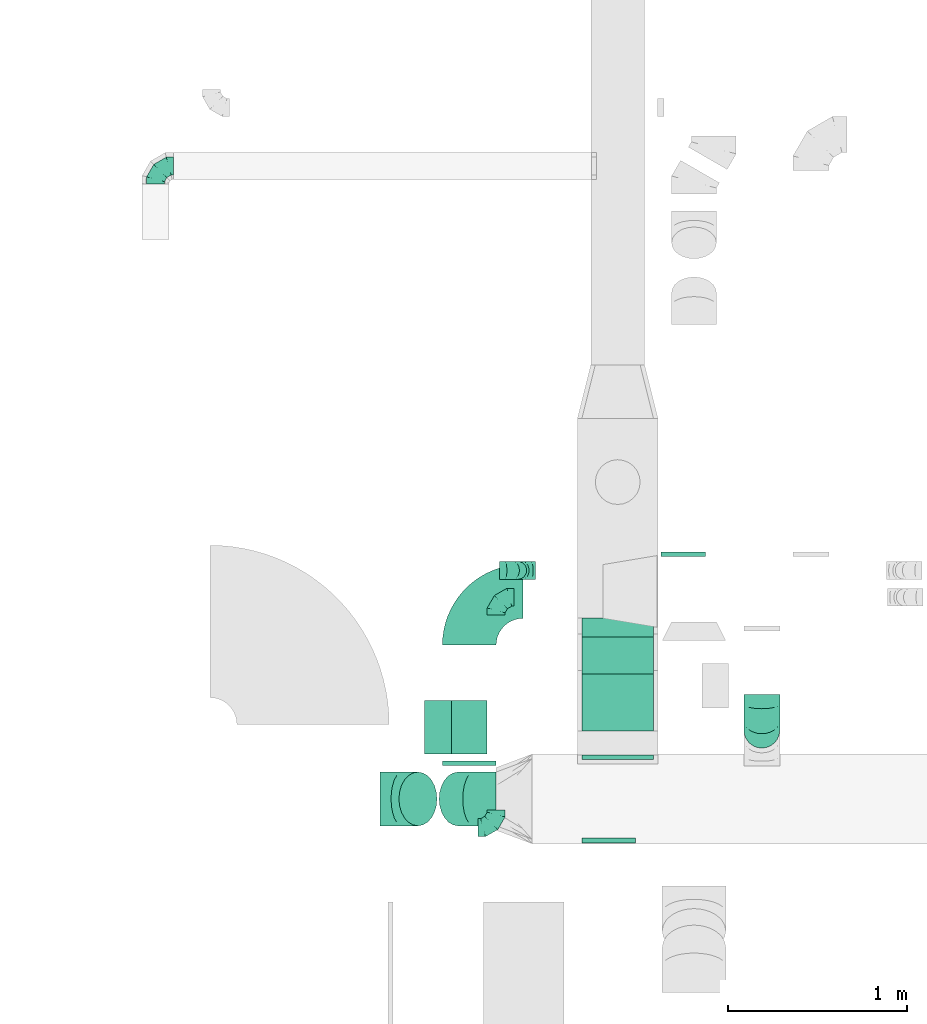
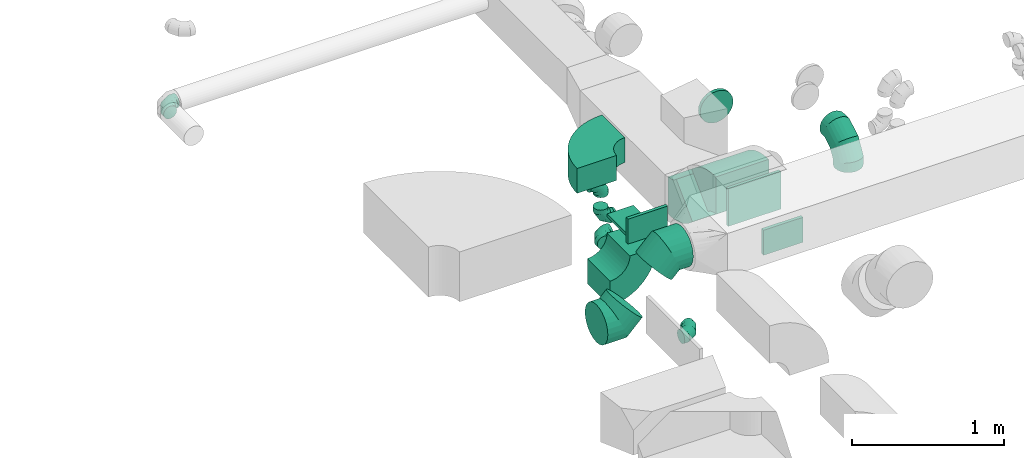
# One storey, part 29 of 62: 17 flow fittings.
"""IFC2X3 building model written with IfcOpenShell, lengths in millimetres."""

from ifc_helpers import new_model, entity, si_unit, converted_unit, derived_unit, direction, frame, frame_2d, origin, origin_2d_with_axis, place, context, subcontext, project, spatial, polyline, circle_curve, parameter, trimmed, segment, composite_curve, rectangle, outline, extrude, faceted_brep, source, transform, mapped, material, type_object, type_shapes, element, save


model = new_model("IFC2X3")

# Units and contexts
model_context = context("Model", 3, precision=0.01, world=origin(), true_north=direction((6.12303176911189e-17, 1.0)))
body_context = subcontext(model_context, "Body", "Model", "MODEL_VIEW")
ifc_project = project(units=[si_unit("LENGTHUNIT", "METRE", prefix="MILLI"), si_unit("AREAUNIT", "SQUARE_METRE"), si_unit("VOLUMEUNIT", "CUBIC_METRE"), converted_unit("PLANEANGLEUNIT", "DEGREE", entity("IfcRatioMeasure", 0.0174532925199433), si_unit("PLANEANGLEUNIT", "RADIAN"), dimensions=[0, 0, 0, 0, 0, 0, 0]), si_unit("MASSUNIT", "GRAM", prefix="KILO"), derived_unit("MASSDENSITYUNIT", [(si_unit("MASSUNIT", "GRAM", prefix="KILO"), 1), (si_unit("LENGTHUNIT", "METRE"), -3)]), derived_unit("MOMENTOFINERTIAUNIT", [(si_unit("LENGTHUNIT", "METRE"), 4)]), si_unit("TIMEUNIT", "SECOND"), si_unit("FREQUENCYUNIT", "HERTZ"), si_unit("THERMODYNAMICTEMPERATUREUNIT", "DEGREE_CELSIUS"), derived_unit("THERMALTRANSMITTANCEUNIT", [(si_unit("MASSUNIT", "GRAM", prefix="KILO"), 1), (si_unit("THERMODYNAMICTEMPERATUREUNIT", "KELVIN"), -1), (si_unit("TIMEUNIT", "SECOND"), -3)]), derived_unit("VOLUMETRICFLOWRATEUNIT", [(si_unit("LENGTHUNIT", "METRE"), 3), (si_unit("TIMEUNIT", "SECOND"), -1)]), derived_unit("MASSFLOWRATEUNIT", [(si_unit("MASSUNIT", "GRAM", prefix="KILO"), 1), (si_unit("TIMEUNIT", "SECOND"), -1)]), derived_unit("ROTATIONALFREQUENCYUNIT", [(si_unit("TIMEUNIT", "SECOND"), -1)]), si_unit("ELECTRICCURRENTUNIT", "AMPERE"), si_unit("ELECTRICVOLTAGEUNIT", "VOLT"), si_unit("POWERUNIT", "WATT"), si_unit("FORCEUNIT", "NEWTON", prefix="KILO"), si_unit("ILLUMINANCEUNIT", "LUX"), si_unit("LUMINOUSFLUXUNIT", "LUMEN"), si_unit("LUMINOUSINTENSITYUNIT", "CANDELA"), derived_unit("USERDEFINED", [(si_unit("MASSUNIT", "GRAM", prefix="KILO"), -1), (si_unit("LENGTHUNIT", "METRE"), -2), (si_unit("TIMEUNIT", "SECOND"), 3), (si_unit("LUMINOUSFLUXUNIT", "LUMEN"), 1)]), derived_unit("LINEARVELOCITYUNIT", [(si_unit("LENGTHUNIT", "METRE"), 1), (si_unit("TIMEUNIT", "SECOND"), -1)]), si_unit("PRESSUREUNIT", "PASCAL"), derived_unit("USERDEFINED", [(si_unit("LENGTHUNIT", "METRE"), -2), (si_unit("MASSUNIT", "GRAM", prefix="KILO"), 1), (si_unit("TIMEUNIT", "SECOND"), -2)]), derived_unit("LINEARFORCEUNIT", [(si_unit("MASSUNIT", "GRAM", prefix="KILO"), 1), (si_unit("LENGTHUNIT", "METRE"), 1), (si_unit("TIMEUNIT", "SECOND"), -2), (si_unit("LENGTHUNIT", "METRE"), -1)]), derived_unit("PLANARFORCEUNIT", [(si_unit("MASSUNIT", "GRAM", prefix="KILO"), 1), (si_unit("LENGTHUNIT", "METRE"), 1), (si_unit("TIMEUNIT", "SECOND"), -2), (si_unit("LENGTHUNIT", "METRE"), -2)])], contexts=[model_context])

# Site, building, storey
site_placement = place(None, origin())
site = spatial("IfcSite", under=ifc_project, at=site_placement, CompositionType="ELEMENT")
building_placement = place(site_placement, origin())
building = spatial("IfcBuilding", under=site, at=building_placement, CompositionType="ELEMENT")
storey_placement = place(building_placement, frame((0.0, 0.0, 24000.0)))
storey = spatial("IfcBuildingStorey", under=building, at=storey_placement, CompositionType="ELEMENT", Elevation=24000.0)

# Flow fittings
ifc_material = material()
duct_fitting_type_1 = type_object("IfcDuctFittingType", PredefinedType="NOTDEFINED", material=ifc_material)
shared_shape_1 = source(origin(), body_context, "Body", "SweptSolid", [
    extrude(rectangle(XDim=26.096000000001, YDim=300.0, at=origin_2d_with_axis()), frame((6.95, 0.0, -100.0)), (0.0, 0.0, 1.0), 200.0),
])
type_shapes(duct_fitting_type_1, [shared_shape_1])
flow_fitting_1_placement = place(storey_placement, frame((39266.85, 9324.41, 3550.0), z_axis=(1.0, 0.0, 0.0), x_axis=(0.0, 0.0, -1.0)))
element("IfcFlowFitting", 1, at=flow_fitting_1_placement, inside=storey, type_object=duct_fitting_type_1, material=ifc_material, context=body_context, shape_type="MappedRepresentation", body=[
    mapped(shared_shape_1, transform((0.0, 0.0, 0.0), scale=1.0)),
])
duct_fitting_type_2 = type_object("IfcDuctFittingType", PredefinedType="NOTDEFINED", material=ifc_material)
shared_shape_2 = source(origin(), body_context, "Body", "SweptSolid", [
    extrude(rectangle(XDim=300.0, YDim=26.096, at=origin_2d_with_axis()), frame((6.95, 0.0, -100.0), z_axis=(0.0, 0.0, 1.0), x_axis=(0.0, -1.0, 0.0)), (0.0, 0.0, 1.0), 200.0),
])
type_shapes(duct_fitting_type_2, [shared_shape_2])
flow_fitting_2_placement = place(storey_placement, frame((40045.11, 8699.98, 3550.0), z_axis=(0.0, 0.0, -1.0), x_axis=(0.0, -1.0, 0.0)))
element("IfcFlowFitting", 2, at=flow_fitting_2_placement, inside=storey, type_object=duct_fitting_type_2, material=ifc_material, context=body_context, shape_type="MappedRepresentation", body=[
    mapped(shared_shape_2, transform((0.0, 0.0, 0.0), scale=1.0)),
])
duct_fitting_type_3 = type_object("IfcDuctFittingType", PredefinedType="NOTDEFINED", material=ifc_material)
shared_shape_3 = source(origin(), body_context, "Body", "SweptSolid", [
    extrude(rectangle(XDim=26.0960000000006, YDim=400.0, at=origin_2d_with_axis()), frame((6.95, 0.0, -150.0)), (0.0, 0.0, 1.0), 300.0),
])
type_shapes(duct_fitting_type_3, [shared_shape_3])
flow_fitting_3_placement = place(storey_placement, frame((40095.11, 9149.98, 3550.0), z_axis=(0.0, 0.0, -1.0), x_axis=(0.0, 1.0, 0.0)))
element("IfcFlowFitting", 3, at=flow_fitting_3_placement, inside=storey, type_object=duct_fitting_type_3, material=ifc_material, context=body_context, shape_type="MappedRepresentation", body=[
    mapped(shared_shape_3, transform((0.0, 0.0, 0.0), scale=1.0)),
])
duct_fitting_type_4 = type_object("IfcDuctFittingType", PredefinedType="NOTDEFINED", material=ifc_material)
shared_shape_4 = source(origin(), body_context, "Body", "SweptSolid", [
    extrude(rectangle(XDim=24.9999999999999, YDim=300.0, at=origin_2d_with_axis()), frame((12.5, 0.0, -100.0)), (0.0, 0.0, 1.0), 200.0),
])
type_shapes(duct_fitting_type_4, [shared_shape_4])
flow_fitting_4_placement = place(storey_placement, frame((39266.85, 9137.41, 3650.0), z_axis=(0.0, 0.0, 1.0), x_axis=(0.0, -1.0, 0.0)))
element("IfcFlowFitting", 4, at=flow_fitting_4_placement, inside=storey, type_object=duct_fitting_type_4, material=ifc_material, context=body_context, shape_type="MappedRepresentation", body=[
    mapped(shared_shape_4, transform((0.0, 0.0, 0.0), scale=1.0)),
])
duct_fitting_type_5 = type_object("IfcDuctFittingType", PredefinedType="NOTDEFINED", material=ifc_material)
shared_shape_5 = source(origin(), body_context, "Body", "Brep", [
    faceted_brep([(-100.0, 0.0, -50.0), (-100.0, -12.94, -48.3), (-100.0, -25.0, -43.3), (-100.0, -35.36, -35.36), (-100.0, -43.3, -25.0), (-100.0, -48.3, -12.94), (-100.0, -50.0, 0.0), (-100.0, -48.3, 12.94), (-100.0, -43.3, 25.0), (-100.0, -35.36, 35.36), (-100.0, -25.0, 43.3), (-100.0, -12.94, 48.3), (-100.0, 0.0, 50.0), (-100.0, 12.94, 48.3), (-100.0, 25.0, 43.3), (-100.0, 35.36, 35.36), (-100.0, 43.3, 25.0), (-100.0, 48.3, 12.94), (-100.0, 50.0, 0.0), (-100.0, 48.3, -12.94), (-100.0, 43.3, -25.0), (-100.0, 35.36, -35.36), (-100.0, 25.0, -43.3), (-100.0, 12.94, -48.3), (-76.67, 12.94, 48.3), (-79.9, 25.0, 43.3), (-73.21, 0.0, 50.0), (-82.68, 35.36, 35.36), (-86.15, 48.3, 12.94), (-86.6, 50.0, 0.0), (-84.81, 43.3, 25.0), (-84.81, 43.3, -25.0), (-82.68, 35.36, -35.36), (-86.15, 48.3, -12.94), (-76.67, 12.94, -48.3), (-73.21, 0.0, -50.0), (-79.9, 25.0, -43.3), (-69.74, -12.94, -48.3), (-66.51, -25.0, -43.3), (-63.73, -35.36, -35.36), (-61.6, -43.3, -25.0), (-60.26, -48.3, -12.94), (-59.81, -50.0, 0.0), (-60.26, -48.3, 12.94), (-61.6, -43.3, 25.0), (-63.73, -35.36, 35.36), (-66.51, -25.0, 43.3), (-69.74, -12.94, 48.3), (-36.27, 36.27, 48.3), (-45.1, 45.1, 43.3), (-26.79, 26.79, 50.0), (-52.68, 52.68, 35.36), (-58.49, 58.49, 25.0), (-62.15, 62.15, 12.94), (-63.4, 63.4, 0.0), (-62.15, 62.15, -12.94), (-58.49, 58.49, -25.0), (-52.68, 52.68, -35.36), (-36.27, 36.27, -48.3), (-26.79, 26.79, -50.0), (-45.1, 45.1, -43.3), (-17.32, 17.32, -48.3), (-8.49, 8.49, -43.3), (-0.91, 0.91, -35.36), (4.9, -4.9, -25.0), (8.56, -8.56, -12.94), (9.81, -9.81, 0.0), (8.56, -8.56, 12.94), (4.9, -4.9, 25.0), (-0.91, 0.91, 35.36), (-8.49, 8.49, 43.3), (-17.32, 17.32, 48.3), (-12.94, 76.67, 48.3), (-25.0, 79.9, 43.3), (0.0, 73.21, 50.0), (-35.36, 82.68, 35.36), (-43.3, 84.81, 25.0), (-48.3, 86.15, 12.94), (-50.0, 86.6, 0.0), (-48.3, 86.15, -12.94), (-43.3, 84.81, -25.0), (-35.36, 82.68, -35.36), (-12.94, 76.67, -48.3), (0.0, 73.21, -50.0), (-25.0, 79.9, -43.3), (12.94, 69.74, -48.3), (25.0, 66.51, -43.3), (35.36, 63.73, -35.36), (43.3, 61.6, -25.0), (48.3, 60.26, -12.94), (50.0, 59.81, 0.0), (48.3, 60.26, 12.94), (43.3, 61.6, 25.0), (35.36, 63.73, 35.36), (25.0, 66.51, 43.3), (12.94, 69.74, 48.3), (-12.94, 100.0, -48.3), (-25.0, 100.0, -43.3), (-35.36, 100.0, -35.36), (-43.3, 100.0, -25.0), (-48.3, 100.0, -12.94), (-50.0, 100.0, 0.0), (-48.3, 100.0, 12.94), (-43.3, 100.0, 25.0), (-35.36, 100.0, 35.36), (-25.0, 100.0, 43.3), (-12.94, 100.0, 48.3), (0.0, 100.0, 50.0), (12.94, 100.0, 48.3), (25.0, 100.0, 43.3), (35.36, 100.0, 35.36), (43.3, 100.0, 25.0), (48.3, 100.0, 12.94), (50.0, 100.0, 0.0), (48.3, 100.0, -12.94), (43.3, 100.0, -25.0), (35.36, 100.0, -35.36), (25.0, 100.0, -43.3), (12.94, 100.0, -48.3), (0.0, 100.0, -50.0)], [[[0, 1, 2, 3, 4, 5, 6, 7, 8, 9, 10, 11, 12, 13, 14, 15, 16, 17, 18, 19, 20, 21, 22, 23]], [[24, 25, 14, 13]], [[26, 24, 13, 12]], [[14, 25, 27, 15]], [[28, 29, 18, 17]], [[30, 28, 17, 16]], [[15, 27, 30, 16]], [[20, 31, 32, 21]], [[33, 31, 20, 19]], [[18, 29, 33, 19]], [[34, 35, 0, 23]], [[36, 34, 23, 22]], [[32, 36, 22, 21]], [[2, 1, 37, 38]], [[3, 2, 38, 39]], [[0, 35, 37, 1]], [[5, 4, 40, 41]], [[6, 5, 41, 42]], [[3, 39, 40, 4]], [[6, 42, 43, 7]], [[7, 43, 44, 8]], [[8, 44, 45, 9]], [[10, 46, 47, 11]], [[11, 47, 26, 12]], [[10, 9, 45, 46]], [[48, 49, 25, 24]], [[50, 48, 24, 26]], [[27, 25, 49, 51]], [[52, 53, 28, 30]], [[51, 52, 30, 27]], [[29, 28, 53, 54]], [[55, 56, 31, 33]], [[54, 55, 33, 29]], [[57, 32, 31, 56]], [[58, 59, 35, 34]], [[60, 58, 34, 36]], [[57, 60, 36, 32]], [[37, 35, 59, 61]], [[38, 37, 61, 62]], [[39, 38, 62, 63]], [[41, 40, 64, 65]], [[42, 41, 65, 66]], [[63, 64, 40, 39]], [[43, 42, 66, 67]], [[44, 43, 67, 68]], [[68, 69, 45, 44]], [[46, 45, 69, 70]], [[47, 46, 70, 71]], [[26, 47, 71, 50]], [[72, 73, 49, 48]], [[74, 72, 48, 50]], [[51, 49, 73, 75]], [[76, 77, 53, 52]], [[75, 76, 52, 51]], [[54, 53, 77, 78]], [[79, 80, 56, 55]], [[78, 79, 55, 54]], [[81, 57, 56, 80]], [[82, 83, 59, 58]], [[84, 82, 58, 60]], [[81, 84, 60, 57]], [[61, 59, 83, 85]], [[62, 61, 85, 86]], [[63, 62, 86, 87]], [[65, 64, 88, 89]], [[66, 65, 89, 90]], [[87, 88, 64, 63]], [[67, 66, 90, 91]], [[68, 67, 91, 92]], [[92, 93, 69, 68]], [[70, 69, 93, 94]], [[71, 70, 94, 95]], [[50, 71, 95, 74]], [[96, 97, 98, 99, 100, 101, 102, 103, 104, 105, 106, 107, 108, 109, 110, 111, 112, 113, 114, 115, 116, 117, 118, 119]], [[72, 74, 107, 106]], [[73, 72, 106, 105]], [[75, 73, 105, 104]], [[77, 76, 103, 102]], [[78, 77, 102, 101]], [[75, 104, 103, 76]], [[78, 101, 100, 79]], [[79, 100, 99, 80]], [[80, 99, 98, 81]], [[96, 119, 83, 82]], [[97, 96, 82, 84]], [[84, 81, 98, 97]], [[83, 119, 118, 85]], [[85, 118, 117, 86]], [[86, 117, 116, 87]], [[88, 115, 114, 89]], [[89, 114, 113, 90]], [[87, 116, 115, 88]], [[91, 90, 113, 112]], [[92, 91, 112, 111]], [[93, 92, 111, 110]], [[95, 94, 109, 108]], [[74, 95, 108, 107]], [[110, 109, 94, 93]]]),
])
type_shapes(duct_fitting_type_5, [shared_shape_5])
flow_fitting_5_placement = place(storey_placement, frame((37517.21, 12455.11, 3200.0), z_axis=(0.0, 0.0, 1.0), x_axis=(-1.0, 0.0, 0.0)))
element("IfcFlowFitting", 5, at=flow_fitting_5_placement, inside=storey, type_object=duct_fitting_type_5, material=ifc_material, context=body_context, shape_type="MappedRepresentation", body=[
    mapped(shared_shape_5, transform((0.0, 0.0, 0.0), scale=1.0)),
])
flow_fitting_6_placement = place(storey_placement, frame((39417.07, 8764.63, 2950.0)))
element("IfcFlowFitting", 6, at=flow_fitting_6_placement, inside=storey, type_object=duct_fitting_type_5, material=ifc_material, context=body_context, shape_type="MappedRepresentation", body=[
    mapped(shared_shape_5, transform((0.0, 0.0, 0.0), scale=1.0)),
])
for number, where, z_axis, x_axis in (
    (7, (39417.07, 10049.93, 2950.0), (0.0, 0.0, 1.0), (-1.0, 0.0, 0.0)),
    (8, (39536.81, 10199.94, 2950.0), (0.0, -1.0, 0.0), (0.0, 0.0, -1.0)),
    (9, (39536.81, 10199.94, 3250.0), (0.0, -1.0, 0.0), (0.0, 0.0, 1.0)),
):
    element("IfcFlowFitting", number, at=place(storey_placement, frame(where, z_axis=z_axis, x_axis=x_axis)), inside=storey, type_object=duct_fitting_type_5, material=ifc_material, context=body_context, shape_type="MappedRepresentation", body=[
        mapped(shared_shape_5, transform((0.0, 0.0, 0.0), scale=1.0)),
    ])
duct_fitting_type_6 = type_object("IfcDuctFittingType", PredefinedType="NOTDEFINED", material=ifc_material)
shared_shape_6 = source(origin(), body_context, "Body", "Brep", [
    faceted_brep([(20.0, 0.0, -125.0), (20.0, 32.35, -120.74), (20.0, 62.5, -108.25), (20.0, 88.39, -88.39), (20.0, 108.25, -62.5), (20.0, 120.74, -32.35), (20.0, 125.0, 0.0), (20.0, 120.74, 32.35), (20.0, 108.25, 62.5), (20.0, 88.39, 88.39), (20.0, 62.5, 108.25), (20.0, 32.35, 120.74), (20.0, 0.0, 125.0), (20.0, -32.35, 120.74), (20.0, -62.5, 108.25), (20.0, -88.39, 88.39), (20.0, -108.25, 62.5), (20.0, -120.74, 32.35), (20.0, -125.0, 0.0), (20.0, -120.74, -32.35), (20.0, -108.25, -62.5), (20.0, -88.39, -88.39), (20.0, -62.5, -108.25), (20.0, -32.35, -120.74), (0.0, 0.0, 125.0), (-6.1, 0.0, 125.0), (-6.1, -32.35, 120.74), (0.0, -32.35, 120.74), (-6.1, -62.5, 108.25), (0.0, -62.5, 108.25), (0.0, -88.39, 88.39), (-6.1, -88.39, 88.39), (0.0, -108.25, 62.5), (-6.1, -108.25, 62.5), (-6.1, -120.74, 32.35), (0.0, -120.74, 32.35), (-6.1, -125.0, 0.0), (0.0, -125.0, 0.0), (-6.1, -120.74, -32.35), (0.0, -120.74, -32.35), (-6.1, -108.25, -62.5), (0.0, -108.25, -62.5), (0.0, -88.39, -88.39), (-6.1, -88.39, -88.39), (0.0, -62.5, -108.25), (-6.1, -62.5, -108.25), (-6.1, -32.35, -120.74), (0.0, -32.35, -120.74), (-6.1, 0.0, -125.0), (0.0, 0.0, -125.0), (-6.1, 32.35, -120.74), (0.0, 32.35, -120.74), (-6.1, 62.5, -108.25), (0.0, 62.5, -108.25), (0.0, 88.39, -88.39), (-6.1, 88.39, -88.39), (0.0, 108.25, -62.5), (-6.1, 108.25, -62.5), (-6.1, 120.74, -32.35), (0.0, 120.74, -32.35), (-6.1, 125.0, 0.0), (0.0, 125.0, 0.0), (-6.1, 120.74, 32.35), (0.0, 120.74, 32.35), (-6.1, 108.25, 62.5), (0.0, 108.25, 62.5), (0.0, 88.39, 88.39), (-6.1, 88.39, 88.39), (0.0, 62.5, 108.25), (-6.1, 62.5, 108.25), (-6.1, 32.35, 120.74), (0.0, 32.35, 120.74)], [[[0, 1, 2, 3, 4, 5, 6, 7, 8, 9, 10, 11, 12, 13, 14, 15, 16, 17, 18, 19, 20, 21, 22, 23]], [[13, 12, 24, 25, 26, 27]], [[14, 13, 27, 26, 28, 29]], [[30, 15, 14, 29, 28, 31]], [[17, 16, 32, 33, 34, 35]], [[18, 17, 35, 34, 36, 37]], [[32, 16, 15, 30, 31, 33]], [[19, 18, 37, 36, 38, 39]], [[20, 19, 39, 38, 40, 41]], [[42, 21, 20, 41, 40, 43]], [[23, 22, 44, 45, 46, 47]], [[0, 23, 47, 46, 48, 49]], [[44, 22, 21, 42, 43, 45]], [[1, 0, 49, 48, 50, 51]], [[2, 1, 51, 50, 52, 53]], [[54, 3, 2, 53, 52, 55]], [[5, 4, 56, 57, 58, 59]], [[6, 5, 59, 58, 60, 61]], [[56, 4, 3, 54, 55, 57]], [[7, 6, 61, 60, 62, 63]], [[8, 7, 63, 62, 64, 65]], [[66, 9, 8, 65, 64, 67]], [[11, 10, 68, 69, 70, 71]], [[12, 11, 71, 70, 25, 24]], [[68, 10, 9, 66, 67, 69]], [[46, 45, 43, 40, 38, 36, 34, 33, 31, 28, 26, 25, 70, 69, 67, 64, 62, 60, 58, 57, 55, 52, 50, 48]]]),
])
type_shapes(duct_fitting_type_6, [shared_shape_6])
flow_fitting_7_placement = place(storey_placement, frame((40460.63, 10282.41, 3475.0), z_axis=(0.0, 1.31217925485646e-06, -1.0), x_axis=(0.0, 1.0, 1.31217925485655e-06)))
element("IfcFlowFitting", 10, at=flow_fitting_7_placement, inside=storey, type_object=duct_fitting_type_6, material=ifc_material, context=body_context, shape_type="MappedRepresentation", body=[
    mapped(shared_shape_6, transform((0.0, 0.0, 0.0), scale=1.0)),
])
duct_fitting_type_7 = type_object("IfcDuctFittingType", PredefinedType="NOTDEFINED", material=ifc_material)
shared_shape_7 = source(origin(), body_context, "Body", "Brep", [
    faceted_brep([(-200.0, 0.0, -100.0), (-200.0, -25.88, -96.59), (-200.0, -50.0, -86.6), (-200.0, -70.71, -70.71), (-200.0, -86.6, -50.0), (-200.0, -96.59, -25.88), (-200.0, -100.0, 0.0), (-200.0, -96.59, 25.88), (-200.0, -86.6, 50.0), (-200.0, -70.71, 70.71), (-200.0, -50.0, 86.6), (-200.0, -25.88, 96.59), (-200.0, 0.0, 100.0), (-200.0, 25.88, 96.59), (-200.0, 50.0, 86.6), (-200.0, 70.71, 70.71), (-200.0, 86.6, 50.0), (-200.0, 96.59, 25.88), (-200.0, 100.0, 0.0), (-200.0, 96.59, -25.88), (-200.0, 86.6, -50.0), (-200.0, 70.71, -70.71), (-200.0, 50.0, -86.6), (-200.0, 25.88, -96.59), (-153.35, 25.88, 96.59), (-159.81, 50.0, 86.6), (-146.41, 0.0, 100.0), (-165.36, 70.71, 70.71), (-172.29, 96.59, 25.88), (-173.21, 100.0, 0.0), (-169.62, 86.6, 50.0), (-169.62, 86.6, -50.0), (-165.36, 70.71, -70.71), (-172.29, 96.59, -25.88), (-153.35, 25.88, -96.59), (-146.41, 0.0, -100.0), (-159.81, 50.0, -86.6), (-139.48, -25.88, -96.59), (-133.01, -50.0, -86.6), (-127.46, -70.71, -70.71), (-123.21, -86.6, -50.0), (-120.53, -96.59, -25.88), (-119.62, -100.0, 0.0), (-120.53, -96.59, 25.88), (-123.21, -86.6, 50.0), (-127.46, -70.71, 70.71), (-133.01, -50.0, 86.6), (-139.48, -25.88, 96.59), (-72.54, 72.54, 96.59), (-90.19, 90.19, 86.6), (-53.59, 53.59, 100.0), (-105.35, 105.35, 70.71), (-116.99, 116.99, 50.0), (-124.3, 124.3, 25.88), (-126.79, 126.79, 0.0), (-124.3, 124.3, -25.88), (-116.99, 116.99, -50.0), (-105.35, 105.35, -70.71), (-72.54, 72.54, -96.59), (-53.59, 53.59, -100.0), (-90.19, 90.19, -86.6), (-34.64, 34.64, -96.59), (-16.99, 16.99, -86.6), (-1.83, 1.83, -70.71), (9.81, -9.81, -50.0), (17.12, -17.12, -25.88), (19.62, -19.62, 0.0), (17.12, -17.12, 25.88), (9.81, -9.81, 50.0), (-1.83, 1.83, 70.71), (-16.99, 16.99, 86.6), (-34.64, 34.64, 96.59), (-25.88, 153.35, 96.59), (-50.0, 159.81, 86.6), (0.0, 146.41, 100.0), (-70.71, 165.36, 70.71), (-86.6, 169.62, 50.0), (-96.59, 172.29, 25.88), (-100.0, 173.21, 0.0), (-96.59, 172.29, -25.88), (-86.6, 169.62, -50.0), (-70.71, 165.36, -70.71), (-25.88, 153.35, -96.59), (0.0, 146.41, -100.0), (-50.0, 159.81, -86.6), (25.88, 139.48, -96.59), (50.0, 133.01, -86.6), (70.71, 127.46, -70.71), (86.6, 123.21, -50.0), (96.59, 120.53, -25.88), (100.0, 119.62, 0.0), (96.59, 120.53, 25.88), (86.6, 123.21, 50.0), (70.71, 127.46, 70.71), (50.0, 133.01, 86.6), (25.88, 139.48, 96.59), (-25.88, 200.0, -96.59), (-50.0, 200.0, -86.6), (-70.71, 200.0, -70.71), (-86.6, 200.0, -50.0), (-96.59, 200.0, -25.88), (-100.0, 200.0, 0.0), (-96.59, 200.0, 25.88), (-86.6, 200.0, 50.0), (-70.71, 200.0, 70.71), (-50.0, 200.0, 86.6), (-25.88, 200.0, 96.59), (0.0, 200.0, 100.0), (25.88, 200.0, 96.59), (50.0, 200.0, 86.6), (70.71, 200.0, 70.71), (86.6, 200.0, 50.0), (96.59, 200.0, 25.88), (100.0, 200.0, 0.0), (96.59, 200.0, -25.88), (86.6, 200.0, -50.0), (70.71, 200.0, -70.71), (50.0, 200.0, -86.6), (25.88, 200.0, -96.59), (0.0, 200.0, -100.0)], [[[0, 1, 2, 3, 4, 5, 6, 7, 8, 9, 10, 11, 12, 13, 14, 15, 16, 17, 18, 19, 20, 21, 22, 23]], [[24, 25, 14, 13]], [[26, 24, 13, 12]], [[14, 25, 27, 15]], [[28, 29, 18, 17]], [[30, 28, 17, 16]], [[15, 27, 30, 16]], [[20, 31, 32, 21]], [[33, 31, 20, 19]], [[18, 29, 33, 19]], [[34, 35, 0, 23]], [[36, 34, 23, 22]], [[32, 36, 22, 21]], [[1, 0, 35, 37]], [[2, 1, 37, 38]], [[38, 39, 3, 2]], [[5, 4, 40, 41]], [[6, 5, 41, 42]], [[39, 40, 4, 3]], [[6, 42, 43, 7]], [[7, 43, 44, 8]], [[8, 44, 45, 9]], [[9, 45, 46, 10]], [[10, 46, 47, 11]], [[26, 12, 11, 47]], [[48, 49, 25, 24]], [[50, 48, 24, 26]], [[27, 25, 49, 51]], [[52, 53, 28, 30]], [[51, 52, 30, 27]], [[29, 28, 53, 54]], [[55, 56, 31, 33]], [[54, 55, 33, 29]], [[32, 31, 56, 57]], [[58, 59, 35, 34]], [[60, 58, 34, 36]], [[57, 60, 36, 32]], [[37, 35, 59, 61]], [[38, 37, 61, 62]], [[39, 38, 62, 63]], [[41, 40, 64, 65]], [[42, 41, 65, 66]], [[63, 64, 40, 39]], [[43, 42, 66, 67]], [[44, 43, 67, 68]], [[68, 69, 45, 44]], [[46, 45, 69, 70]], [[47, 46, 70, 71]], [[26, 47, 71, 50]], [[72, 73, 49, 48]], [[74, 72, 48, 50]], [[51, 49, 73, 75]], [[76, 77, 53, 52]], [[75, 76, 52, 51]], [[54, 53, 77, 78]], [[79, 80, 56, 55]], [[78, 79, 55, 54]], [[57, 56, 80, 81]], [[82, 83, 59, 58]], [[84, 82, 58, 60]], [[81, 84, 60, 57]], [[61, 59, 83, 85]], [[62, 61, 85, 86]], [[63, 62, 86, 87]], [[65, 64, 88, 89]], [[66, 65, 89, 90]], [[87, 88, 64, 63]], [[67, 66, 90, 91]], [[68, 67, 91, 92]], [[92, 93, 69, 68]], [[70, 69, 93, 94]], [[71, 70, 94, 95]], [[50, 71, 95, 74]], [[96, 97, 98, 99, 100, 101, 102, 103, 104, 105, 106, 107, 108, 109, 110, 111, 112, 113, 114, 115, 116, 117, 118, 119]], [[72, 74, 107, 106]], [[73, 72, 106, 105]], [[75, 73, 105, 104]], [[102, 101, 78, 77]], [[103, 102, 77, 76]], [[75, 104, 103, 76]], [[78, 101, 100, 79]], [[79, 100, 99, 80]], [[80, 99, 98, 81]], [[84, 97, 96, 82]], [[82, 96, 119, 83]], [[84, 81, 98, 97]], [[118, 117, 86, 85]], [[119, 118, 85, 83]], [[116, 87, 86, 117]], [[88, 115, 114, 89]], [[89, 114, 113, 90]], [[115, 88, 87, 116]], [[91, 90, 113, 112]], [[92, 91, 112, 111]], [[111, 110, 93, 92]], [[95, 94, 109, 108]], [[74, 95, 108, 107]], [[110, 109, 94, 93]]]),
])
type_shapes(duct_fitting_type_7, [shared_shape_7])
flow_fitting_8_placement = place(storey_placement, frame((40899.04, 9308.41, 3650.0), z_axis=(1.0, 0.0, 0.0), x_axis=(0.0, -1.0, 0.0)))
element("IfcFlowFitting", 11, at=flow_fitting_8_placement, inside=storey, type_object=duct_fitting_type_7, material=ifc_material, context=body_context, shape_type="MappedRepresentation", body=[
    mapped(shared_shape_7, transform((0.0, 0.0, 0.0), scale=1.0)),
])
duct_fitting_type_8 = type_object("IfcDuctFittingType", PredefinedType="NOTDEFINED", material=ifc_material)
shared_shape_8 = source(origin(), body_context, "Body", "Brep", [
    faceted_brep([(-124.26, 0.0, -150.0), (-124.26, -38.82, -144.89), (-124.26, -75.0, -129.9), (-124.26, -106.07, -106.07), (-124.26, -129.9, -75.0), (-124.26, -144.89, -38.82), (-124.26, -150.0, 0.0), (-124.26, -144.89, 38.82), (-124.26, -129.9, 75.0), (-124.26, -106.07, 106.07), (-124.26, -75.0, 129.9), (-124.26, -38.82, 144.89), (-124.26, 0.0, 150.0), (-124.26, 38.82, 144.89), (-124.26, 75.0, 129.9), (-124.26, 106.07, 106.07), (-124.26, 129.9, 75.0), (-124.26, 144.89, 38.82), (-124.26, 150.0, 0.0), (-124.26, 144.89, -38.82), (-124.26, 129.9, -75.0), (-124.26, 106.07, -106.07), (-124.26, 75.0, -129.9), (-124.26, 38.82, -144.89), (-16.08, 38.82, 144.89), (-31.07, 75.0, 129.9), (0.0, 0.0, 150.0), (-43.93, 106.07, 106.07), (-60.01, 144.89, 38.82), (-62.13, 150.0, 0.0), (-53.81, 129.9, 75.0), (-53.81, 129.9, -75.0), (-43.93, 106.07, -106.07), (-60.01, 144.89, -38.82), (-16.08, 38.82, -144.89), (0.0, 0.0, -150.0), (-31.07, 75.0, -129.9), (16.08, -38.82, -144.89), (31.07, -75.0, -129.9), (43.93, -106.07, -106.07), (53.81, -129.9, -75.0), (60.01, -144.89, -38.82), (62.13, -150.0, 0.0), (60.01, -144.89, 38.82), (53.81, -129.9, 75.0), (43.93, -106.07, 106.07), (31.07, -75.0, 129.9), (16.08, -38.82, 144.89), (87.87, 87.87, 150.0), (60.42, 115.32, 144.89), (34.83, 140.9, 129.9), (12.87, 162.87, 106.07), (-3.99, 179.72, 75.0), (-14.58, 190.32, 38.82), (-18.2, 193.93, 0.0), (-14.58, 190.32, -38.82), (-3.99, 179.72, -75.0), (12.87, 162.87, -106.07), (34.83, 140.9, -129.9), (60.42, 115.32, -144.89), (87.87, 87.87, -150.0), (115.32, 60.42, -144.89), (140.9, 34.83, -129.9), (162.87, 12.87, -106.07), (179.72, -3.99, -75.0), (190.32, -14.58, -38.82), (193.93, -18.2, 0.0), (190.32, -14.58, 38.82), (179.72, -3.99, 75.0), (162.87, 12.87, 106.07), (140.9, 34.83, 129.9), (115.32, 60.42, 144.89)], [[[0, 1, 2, 3, 4, 5, 6, 7, 8, 9, 10, 11, 12, 13, 14, 15, 16, 17, 18, 19, 20, 21, 22, 23]], [[24, 25, 14, 13]], [[26, 24, 13, 12]], [[14, 25, 27, 15]], [[28, 29, 18, 17]], [[30, 28, 17, 16]], [[15, 27, 30, 16]], [[20, 31, 32, 21]], [[33, 31, 20, 19]], [[18, 29, 33, 19]], [[34, 35, 0, 23]], [[36, 34, 23, 22]], [[32, 36, 22, 21]], [[1, 0, 35, 37]], [[2, 1, 37, 38]], [[38, 39, 3, 2]], [[5, 4, 40, 41]], [[6, 5, 41, 42]], [[39, 40, 4, 3]], [[6, 42, 43, 7]], [[7, 43, 44, 8]], [[8, 44, 45, 9]], [[9, 45, 46, 10]], [[10, 46, 47, 11]], [[26, 12, 11, 47]], [[24, 26, 48, 49]], [[25, 24, 49, 50]], [[27, 25, 50, 51]], [[28, 30, 52, 53]], [[29, 28, 53, 54]], [[51, 52, 30, 27]], [[29, 54, 55, 33]], [[33, 55, 56, 31]], [[57, 32, 31, 56]], [[36, 58, 59, 34]], [[34, 59, 60, 35]], [[58, 36, 32, 57]], [[35, 60, 61, 37]], [[37, 61, 62, 38]], [[63, 39, 38, 62]], [[40, 64, 65, 41]], [[41, 65, 66, 42]], [[64, 40, 39, 63]], [[43, 42, 66, 67]], [[44, 43, 67, 68]], [[68, 69, 45, 44]], [[47, 46, 70, 71]], [[26, 47, 71, 48]], [[69, 70, 46, 45]], [[59, 58, 57, 56, 55, 54, 53, 52, 51, 50, 49, 48, 71, 70, 69, 68, 67, 66, 65, 64, 63, 62, 61, 60]]]),
])
type_shapes(duct_fitting_type_8, [shared_shape_8])
for number, where, z_axis, x_axis in (
    (12, (39292.8, 8924.98, 3550.0), (0.0, -1.0, 0.0), (-1.0, 0.0, 0.0)),
    (13, (38892.8, 8924.98, 3150.0), (0.0, 1.0, 0.0), (-0.70710678118652, 0.0, -0.707106781186575)),
):
    element("IfcFlowFitting", number, at=place(storey_placement, frame(where, z_axis=z_axis, x_axis=x_axis)), inside=storey, type_object=duct_fitting_type_8, material=ifc_material, context=body_context, shape_type="MappedRepresentation", body=[
        mapped(shared_shape_8, transform((0.0, 0.0, 0.0), scale=1.0)),
    ])
duct_fitting_type_9 = type_object("IfcDuctFittingType", PredefinedType="NOTDEFINED", material=ifc_material)
shared_shape_9 = source(origin(), body_context, "Body", "SweptSolid", [
    extrude(outline(composite_curve([segment(polyline([(-300.0, -150.0), (0.0, -150.0)]), True, "CONTINUOUS"), segment(trimmed(circle_curve(frame_2d((150.0, -150.0), x_axis=(0.0, 1.0)), 150.0), [parameter(0.0)], [parameter(90.0)], True, "PARAMETER"), False, "CONTINUOUS"), segment(polyline([(150.0, 0.0), (150.0, 300.0)]), True, "CONTINUOUS"), segment(trimmed(circle_curve(frame_2d((150.0, -150.0), x_axis=(0.0, 1.0)), 450.0), [parameter(0.0)], [parameter(90.0000000000001)], True, "PARAMETER"), True, "CONTINUOUS")], self_intersect=False)), frame((-150.0, 150.0, -100.0), z_axis=(0.0, 0.0, 1.0), x_axis=(-1.0, 0.0, 0.0)), (0.0, 0.0, 1.0), 200.0),
])
type_shapes(duct_fitting_type_9, [shared_shape_9])
flow_fitting_9_placement = place(storey_placement, frame((39266.85, 10082.41, 3650.0), z_axis=(0.0, 0.0, 1.0), x_axis=(-1.0, 0.0, 0.0)))
element("IfcFlowFitting", 14, at=flow_fitting_9_placement, inside=storey, type_object=duct_fitting_type_9, material=ifc_material, context=body_context, shape_type="MappedRepresentation", body=[
    mapped(shared_shape_9, transform((0.0, 0.0, 0.0), scale=1.0)),
])
duct_fitting_type_10 = type_object("IfcDuctFittingType", PredefinedType="NOTDEFINED", material=ifc_material)
shared_shape_10 = source(origin(), body_context, "Body", "SweptSolid", [
    extrude(outline(composite_curve([segment(polyline([(-193.93, -106.07), (106.07, -106.07)]), True, "CONTINUOUS"), segment(trimmed(circle_curve(frame_2d((256.07, -106.07), x_axis=(-0.707106781186553, 0.707106781186553)), 150.0), [parameter(0.0)], [parameter(45.0)], True, "PARAMETER"), False, "CONTINUOUS"), segment(polyline([(150.0, 0.0), (-62.13, 212.13)]), True, "CONTINUOUS"), segment(trimmed(circle_curve(frame_2d((256.07, -106.07), x_axis=(-0.707106781186553, 0.707106781186553)), 450.0), [parameter(0.0)], [parameter(45.0)], True, "PARAMETER"), True, "CONTINUOUS")], self_intersect=False)), frame((-18.2, 43.93, -200.0), z_axis=(0.0, 0.0, 1.0), x_axis=(-0.707106781186547, 0.707106781186548, 0.0)), (0.0, 0.0, 1.0), 400.0),
])
type_shapes(duct_fitting_type_10, [shared_shape_10])
for number, where, z_axis, x_axis in (
    (15, (40095.11, 9809.38, 3170.0), (-1.0, 0.0, 0.0), (0.0, -1.0, 0.0)),
    (16, (40095.11, 9429.38, 3550.0), (-1.0, 0.0, 0.0), (0.0, 1.0, 0.0)),
):
    element("IfcFlowFitting", number, at=place(storey_placement, frame(where, z_axis=z_axis, x_axis=x_axis)), inside=storey, type_object=duct_fitting_type_10, material=ifc_material, context=body_context, shape_type="MappedRepresentation", body=[
        mapped(shared_shape_10, transform((0.0, 0.0, 0.0), scale=1.0)),
    ])
duct_fitting_type_11 = type_object("IfcDuctFittingType", PredefinedType="NOTDEFINED", material=ifc_material)
shared_shape_11 = source(origin(), body_context, "Body", "SweptSolid", [
    extrude(outline(composite_curve([segment(polyline([(-225.0, -125.0), (-25.0, -125.0)]), True, "CONTINUOUS"), segment(trimmed(circle_curve(frame_2d((125.0, -125.0), x_axis=(0.0, 1.0)), 150.0), [parameter(0.0)], [parameter(90.0)], True, "PARAMETER"), False, "CONTINUOUS"), segment(polyline([(125.0, 25.0), (125.0, 225.0)]), True, "CONTINUOUS"), segment(trimmed(circle_curve(frame_2d((125.0, -125.0), x_axis=(0.0, 1.0)), 350.0), [parameter(0.0)], [parameter(90.0)], True, "PARAMETER"), True, "CONTINUOUS")], self_intersect=False)), frame((-125.0, 125.0, -150.0), z_axis=(0.0, 0.0, 1.0), x_axis=(-1.0, 0.0, 0.0)), (0.0, 0.0, 1.0), 300.0),
])
type_shapes(duct_fitting_type_11, [shared_shape_11])
flow_fitting_10_placement = place(storey_placement, frame((39266.85, 9324.41, 3150.0), z_axis=(0.0, -1.0, 0.0), x_axis=(1.0, 0.0, 0.0)))
element("IfcFlowFitting", 17, at=flow_fitting_10_placement, inside=storey, type_object=duct_fitting_type_11, material=ifc_material, context=body_context, shape_type="MappedRepresentation", body=[
    mapped(shared_shape_11, transform((0.0, 0.0, 0.0), scale=1.0)),
])

save(model, "model.ifc")
